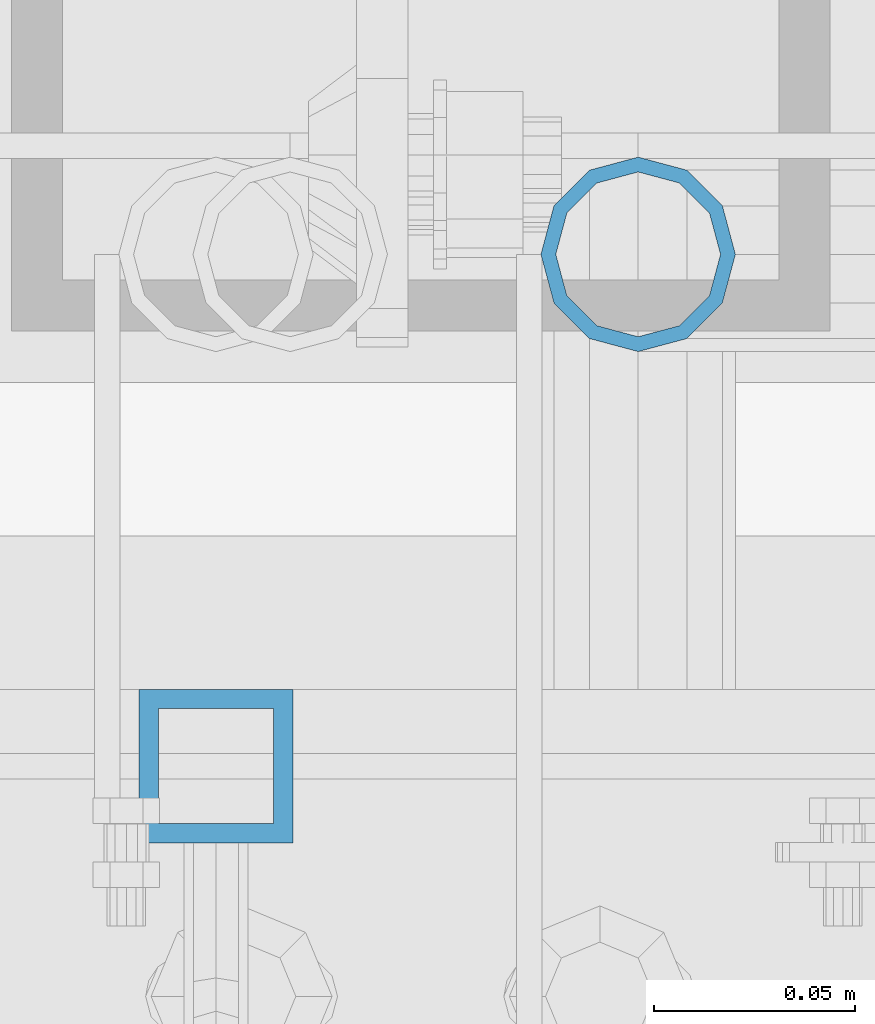
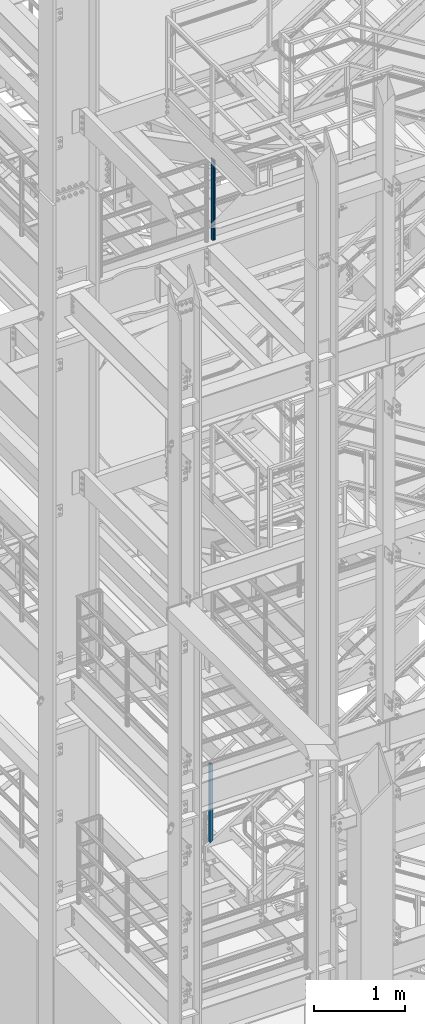
# One storey, part 609 of 1876: 2 columns, 2 elements without a shape of their own.
"""IFC2X3 building model written with IfcOpenShell, lengths in millimetres."""

import ifcopenshell
import ifcopenshell.guid

model = None  # the IFC model being written
_history = None  # IfcOwnerHistory: only IFC2X3 demands one
_inside = {}  # id of a spatial element -> (the spatial element, [elements in it])
_under = {}  # id of a project, library or spatial element -> (it, [spatial elements below it])
_declared = {}  # id of a project -> (the project, [libraries it declares])
_typed = {}  # id of a type object -> (the type object, [elements of that type])
_made_of = {}  # id of a material, layer set ... -> (it, [elements and type objects made of it])


def new_model(schema):
    """Start an empty IFC model of exactly this schema.

    Asked for "IFC4X3", IfcOpenShell would pick the latest addendum, in which some entities
    have other attributes; the version numbers below select the first issue.
    IFC2X3 requires an IfcOwnerHistory on every rooted entity: one is made here for all.
    """
    global model, _history
    if schema == "IFC4X3":
        model = ifcopenshell.file(schema_version=(4, 3, 0, 0))
    else:
        model = ifcopenshell.file(schema=schema)
    _inside.clear()
    _under.clear()
    _declared.clear()
    _typed.clear()
    _made_of.clear()
    _history = None
    if model.schema == "IFC2X3":
        org = make("IfcOrganization", Name="unknown")
        user = make(
            "IfcPersonAndOrganization",
            ThePerson=make("IfcPerson", FamilyName="unknown"),
            TheOrganization=org,
        )
        app = make(
            "IfcApplication",
            ApplicationDeveloper=org,
            Version="unknown",
            ApplicationFullName="unknown",
            ApplicationIdentifier="unknown",
        )
        _history = make(
            "IfcOwnerHistory",
            OwningUser=user,
            OwningApplication=app,
            ChangeAction="ADDED",
            CreationDate=0,
        )
    return model


def make(cls, **values):
    """One entity of the class cls with the attributes given. An attribute that is None is left unset."""
    return model.create_entity(
        cls, **{name: value for name, value in values.items() if value is not None}
    )


def rooted(cls, **values):
    """An entity with a GlobalId (a new one), such as an element, a storey or a relation."""
    return make(cls, GlobalId=ifcopenshell.guid.new(), OwnerHistory=_history, **values)


def si_unit(unit_type, name, prefix=None):
    """IfcSIUnit, for example si_unit("LENGTHUNIT", "METRE", prefix="MILLI")."""
    return make("IfcSIUnit", UnitType=unit_type, Prefix=prefix, Name=name)


def assignment(units):
    """IfcUnitAssignment: the units of a project."""
    return None if units is None else make("IfcUnitAssignment", Units=units)


def point(xyz):
    """IfcCartesianPoint."""
    return None if xyz is None else make("IfcCartesianPoint", Coordinates=xyz)


def direction(xyz):
    """IfcDirection."""
    return None if xyz is None else make("IfcDirection", DirectionRatios=xyz)


def frame(location, z_axis=None, x_axis=None):
    """IfcAxis2Placement3D, a coordinate frame: its origin and axes. An axis left out is left unset."""
    return make(
        "IfcAxis2Placement3D",
        Location=point(location),
        Axis=direction(z_axis),
        RefDirection=direction(x_axis),
    )


def origin_with_axes():
    """The frame at (0, 0, 0) with the z axis (0, 0, 1) and the x axis (1, 0, 0) written out."""
    return frame((0.0, 0.0, 0.0), z_axis=(0.0, 0.0, 1.0), x_axis=(1.0, 0.0, 0.0))


def place(relative_to, where):
    """IfcLocalPlacement: puts the frame where relative to a parent placement (None: the world)."""
    return make(
        "IfcLocalPlacement", PlacementRelTo=relative_to, RelativePlacement=where
    )


def context(
    kind, dimensions, precision=None, world=None, true_north=None, identifier=None
):
    """IfcGeometricRepresentationContext, for example the 3D "Model" context."""
    return make(
        "IfcGeometricRepresentationContext",
        ContextIdentifier=identifier,
        ContextType=kind,
        CoordinateSpaceDimension=dimensions,
        Precision=precision,
        WorldCoordinateSystem=world,
        TrueNorth=true_north,
    )


def subcontext(parent, identifier, kind, view, scale=None):
    """IfcGeometricRepresentationSubContext, for example "Body" below "Model"."""
    return make(
        "IfcGeometricRepresentationSubContext",
        ContextIdentifier=identifier,
        ContextType=kind,
        ParentContext=parent,
        TargetScale=scale,
        TargetView=view,
    )


def project(units=None, contexts=None):
    """IfcProject with its units and contexts."""
    return rooted(
        "IfcProject",
        Name="project",
        RepresentationContexts=contexts,
        UnitsInContext=assignment(units),
    )


def spatial(cls, under=None, at=None, **own):
    """A site, building, storey or space (cls), placed at a placement, below another one or the project."""
    s = rooted(cls, ObjectPlacement=at, **own)
    if under is not None:
        _under.setdefault(under.id(), (under, []))[1].append(s)
    return s


def faces_of(points, faces, orient=None, outer=None):
    """IfcFace entities. A face is a list of loops; a loop is a list of indices into points, from 0.

    orient and outer hold one flag for each loop. By default every Orientation is true, the
    first loop of a face is its IfcFaceOuterBound and the others are IfcFaceBound.
    """
    made = []
    for i, loops in enumerate(faces):
        bounds = []
        for j, loop in enumerate(loops):
            is_outer = j == 0 if outer is None else outer[i][j]
            bounds.append(
                make(
                    "IfcFaceOuterBound" if is_outer else "IfcFaceBound",
                    Bound=make("IfcPolyLoop", Polygon=[points[k] for k in loop]),
                    Orientation=True if orient is None else orient[i][j],
                )
            )
        made.append(make("IfcFace", Bounds=bounds))
    return made


def faceted_brep(points, faces, orient=None, outer=None, voids=None):
    """IfcFacetedBrep: a solid bounded by flat faces; with voids (closed shells), ...WithVoids."""
    shared = [point(p) for p in points]
    hull = make("IfcClosedShell", CfsFaces=faces_of(shared, faces, orient, outer))
    if voids is None:
        return make("IfcFacetedBrep", Outer=hull)
    return make(
        "IfcFacetedBrepWithVoids",
        Outer=hull,
        Voids=[
            make(cls, CfsFaces=faces_of(shared, fs, o, b)) for cls, fs, o, b in voids
        ],
    )


def shape(context_of_items, identifier, shape_type, items):
    """IfcShapeRepresentation: the items that make up one representation, for example the "Body"."""
    return make(
        "IfcShapeRepresentation",
        ContextOfItems=context_of_items,
        RepresentationIdentifier=identifier,
        RepresentationType=shape_type,
        Items=items,
    )


def material(Name=None, Category=None):
    """IfcMaterial."""
    return make("IfcMaterial", Name=Name, Category=Category)


def made_of(thing, what):
    """Note that an element or type object is made of a material, layer set ...; save() writes the relation."""
    if what is not None:
        _made_of.setdefault(what.id(), (what, []))[1].append(thing)
    return thing


def type_object(cls, material=None, **own):
    """A type object (cls), such as IfcWallType, which elements share."""
    return made_of(rooted(cls, **own), material)


def element(
    cls,
    number,
    at=None,
    inside=None,
    cuts=None,
    type_object=None,
    material=None,
    context=None,
    identifier="Body",
    shape_type=None,
    held_by="IfcProductDefinitionShape",
    body=None,
    shapes=None,
    **own,
):
    """One element of the class cls, such as IfcWall. Its Tag is "e" and its number.

    at: its placement. inside: the storey or other place that contains it. cuts: it is an
    opening in that element (IfcRelVoidsElement). A single representation is given by context,
    identifier, shape_type and body (its items); several are given by shapes. held_by: the class
    of the entity that holds the representations. save() writes the other relations.
    """
    e = rooted(cls, Tag="e%d" % number, ObjectPlacement=at, **own)
    if body is not None:
        shapes = [shape(context, identifier, shape_type, body)]
    if shapes is not None:
        e.Representation = make(held_by, Representations=shapes)
    if inside is not None:
        _inside.setdefault(inside.id(), (inside, []))[1].append(e)
    if cuts is not None:
        rooted(
            "IfcRelVoidsElement", RelatingBuildingElement=cuts, RelatedOpeningElement=e
        )
    if type_object is not None:
        _typed.setdefault(type_object.id(), (type_object, []))[1].append(e)
    return made_of(e, material)


def aggregate(whole, parts):
    """IfcRelAggregates: a whole, such as a stair, and the parts it consists of."""
    return rooted("IfcRelAggregates", RelatingObject=whole, RelatedObjects=parts)


def save(model, path):
    """Write the relations noted so far, then the file.

    IfcRelAggregates (storeys below a building ...), IfcRelContainedInSpatialStructure (elements
    in a storey), IfcRelDefinesByType, IfcRelAssociatesMaterial and IfcRelDeclares: one each for
    every whole, place, type object, material and project.
    """
    for whole, parts in _under.values():
        aggregate(whole, parts)
    for where, things in _inside.values():
        rooted(
            "IfcRelContainedInSpatialStructure",
            RelatedElements=things,
            RelatingStructure=where,
        )
    for kind, things in _typed.values():
        rooted("IfcRelDefinesByType", RelatedObjects=things, RelatingType=kind)
    for what, things in _made_of.values():
        rooted("IfcRelAssociatesMaterial", RelatedObjects=things, RelatingMaterial=what)
    for by, libraries in _declared.values():
        rooted("IfcRelDeclares", RelatingContext=by, RelatedDefinitions=libraries)
    model.write(path)


model = new_model("IFC2X3")

# Units and contexts
model_context = context("Model", 3, precision=1e-05, world=origin_with_axes())
body_context = subcontext(model_context, "Body", "Model", "MODEL_VIEW")
ifc_project = project(units=[si_unit("LENGTHUNIT", "METRE", prefix="MILLI"), si_unit("AREAUNIT", "SQUARE_METRE"), si_unit("VOLUMEUNIT", "CUBIC_METRE"), si_unit("MASSUNIT", "GRAM", prefix="KILO"), si_unit("TIMEUNIT", "SECOND"), si_unit("PLANEANGLEUNIT", "RADIAN"), si_unit("SOLIDANGLEUNIT", "STERADIAN"), si_unit("THERMODYNAMICTEMPERATUREUNIT", "DEGREE_CELSIUS"), si_unit("LUMINOUSINTENSITYUNIT", "LUMEN")], contexts=[model_context])

# Site, building, storey
site_placement = place(None, origin_with_axes())
site = spatial("IfcSite", under=ifc_project, at=site_placement, CompositionType="ELEMENT")
building_placement = place(site_placement, origin_with_axes())
building = spatial("IfcBuilding", under=site, at=building_placement, Name="Undefined", CompositionType="ELEMENT")
storey_placement = place(building_placement, origin_with_axes())
storey = spatial("IfcBuildingStorey", under=building, at=storey_placement, Name="Undefined", CompositionType="ELEMENT", Elevation=0.0)

# Assembly, column
assembly_1_placement = place(storey_placement, origin_with_axes())
assembly_1 = element("IfcElementAssembly", 1, at=assembly_1_placement, inside=storey, Name="RAIL", AssemblyPlace="NOTDEFINED", PredefinedType="RIGID_FRAME")
ifc_material_1 = material()
column_type_1 = type_object("IfcColumnType", Name="HSS1-1/2X1-1/2X3/16", PredefinedType="NOTDEFINED")
column_1_placement = place(assembly_1_placement, frame((1676.40000031139, -4781.55000114554, 5380.55913466399), z_axis=(-1.0, 0.0, 0.0), x_axis=(0.0, 0.0, 1.0)))
column_1 = element("IfcColumn", 2, at=column_1_placement, type_object=column_type_1, material=ifc_material_1, Name="POST", ObjectType="HSS1-1/2X1-1/2X3/16", context=body_context, shape_type="Brep", body=[
    faceted_brep([(9.09204508312268, 14.2874994260001, -14.2874994260001), (9.09204508312268, -14.2874994260001, -14.2874994260001), (1028.85007387741, -14.2874994260001, -14.2874994260001), (1028.85007387741, 14.2874994260001, -14.2874994260001), (-9.09204508310631, -14.2874994260001, 14.2874994260001), (1044.53620210125, -14.2874994260001, 14.2874994260001), (-9.09204508310631, 14.2874994260001, 14.2874994260001), (1044.53620210125, 14.2874994260001, 14.2874994260001), (12.1227267777067, 19.0499992349996, -19.0499992349996), (-12.1227267776903, 19.0499992349996, 19.0499992349996), (1047.15055680541, 19.0499992349996, 19.0499992350001), (1026.23571825648, 19.0499992349996, -19.0499992349996), (-12.1227267776903, -19.0499992349996, 19.0499992349996), (1047.15055680541, -19.0499992349996, 19.0499992350001), (12.1227267777067, -19.0499992349996, -19.0499992349996), (1026.23571825648, -19.0500000000002, -19.0499992349996)], [[[0, 1, 2, 3]], [[1, 4, 5, 2]], [[4, 6, 7, 5]], [[6, 0, 3, 7]], [[8, 9, 10, 11]], [[9, 12, 13, 10]], [[12, 14, 15, 13]], [[14, 8, 11, 15]], [[13, 15, 11, 10], [5, 7, 3, 2]], [[14, 12, 9, 8], [6, 4, 1, 0]]]),
])
aggregate(assembly_1, [column_1])

assembly_2_placement = place(storey_placement, origin_with_axes())
assembly_2 = element("IfcElementAssembly", 3, at=assembly_2_placement, inside=storey, Name="RAIL", AssemblyPlace="NOTDEFINED", PredefinedType="RIGID_FRAME")
ifc_material_2 = material()
column_type_2 = type_object("IfcColumnType", Name="PIPE1-1/2SCH40", PredefinedType="NOTDEFINED")
column_2_placement = place(assembly_2_placement, frame((1781.175, -4654.55000114554, 13309.6), z_axis=(0.0, 1.0, 0.0), x_axis=(0.0, 0.0, 1.0)))
column_2 = element("IfcColumn", 4, at=column_2_placement, type_object=column_type_2, material=ifc_material_2, Name="POST", ObjectType="PIPE1-1/2SCH40", context=body_context, shape_type="Brep", body=[
    faceted_brep([(0.0, -20.4469999999999, 0.0), (0.0, -17.7076214311803, 10.2235000000001), (1094.03262143118, -17.7076214311804, 10.2235000000001), (1096.772, -20.447, 0.0), (0.0, -10.2235000000001, 17.7076214311801), (1086.5485, -10.2235, 17.7076214311801), (-1.45519152283669e-11, 0.0, 20.4470000000001), (1076.325, 0.0, 20.4470000000001), (0.0, 10.2235000000001, 17.7076214311801), (1066.1015, 10.2235, 17.7076214311801), (0.0, 17.7076214311803, 10.2235000000001), (1058.61737856882, 17.7076214311804, 10.2235000000001), (0.0, 20.4469999999999, 0.0), (1055.878, 20.447, 0.0), (0.0, 17.7076214311803, -10.2235000000001), (1058.61737856882, 17.7076214311804, -10.2235000000001), (0.0, 10.2235000000001, -17.7076214311801), (1066.1015, 10.2235, -17.7076214311801), (-1.45519152283669e-11, 0.0, -20.4470000000001), (1076.325, 0.0, -20.4470000000001), (0.0, -10.2235000000001, -17.7076214311801), (1086.5485, -10.2235, -17.7076214311801), (0.0, -17.7076214311803, -10.2235000000001), (1094.03262143118, -17.7076214311804, -10.2235000000001), (0.0, -24.1299999999992, 0.0), (0.0, -20.8971929933184, -12.0649999999996), (1097.22219299332, -20.8971929933185, -12.0649999999996), (1100.455, -24.13, 0.0), (0.0, -12.0650000000001, -20.8971929933186), (1088.39, -12.065, -20.8971929933186), (-1.45519152283669e-11, 0.0, -24.130000000001), (1076.325, 0.0, -24.1300000000001), (0.0, 12.0650000000001, -20.8971929933186), (1064.26, 12.065, -20.8971929933186), (0.0, 20.8971929933184, -12.0649999999996), (1055.42780700668, 20.8971929933185, -12.0649999999996), (0.0, 24.1299999999992, 0.0), (1052.195, 24.13, 0.0), (0.0, 20.8971929933184, 12.0649999999996), (1055.42780700668, 20.8971929933185, 12.0649999999996), (0.0, 12.0650000000001, 20.8971929933186), (1064.26, 12.065, 20.8971929933186), (-1.45519152283669e-11, 0.0, 24.130000000001), (1076.325, 0.0, 24.1300000000001), (0.0, -12.0650000000001, 20.8971929933186), (1088.39, -12.065, 20.8971929933186), (0.0, -20.8971929933184, 12.0649999999996), (1097.22219299332, -20.8971929933185, 12.0649999999996)], [[[0, 1, 2, 3]], [[1, 4, 5, 2]], [[4, 6, 7, 5]], [[6, 8, 9, 7]], [[8, 10, 11, 9]], [[10, 12, 13, 11]], [[12, 14, 15, 13]], [[14, 16, 17, 15]], [[16, 18, 19, 17]], [[18, 20, 21, 19]], [[20, 22, 23, 21]], [[22, 0, 3, 23]], [[24, 25, 26, 27]], [[25, 28, 29, 26]], [[28, 30, 31, 29]], [[30, 32, 33, 31]], [[32, 34, 35, 33]], [[34, 36, 37, 35]], [[36, 38, 39, 37]], [[38, 40, 41, 39]], [[40, 42, 43, 41]], [[42, 44, 45, 43]], [[44, 46, 47, 45]], [[46, 24, 27, 47]], [[29, 31, 33, 35, 37, 39, 41, 43, 45, 47, 27, 26], [5, 7, 9, 11, 13, 15, 17, 19, 21, 23, 3, 2]], [[46, 44, 42, 40, 38, 36, 34, 32, 30, 28, 25, 24], [22, 20, 18, 16, 14, 12, 10, 8, 6, 4, 1, 0]]]),
])
aggregate(assembly_2, [column_2])

save(model, "model.ifc")
